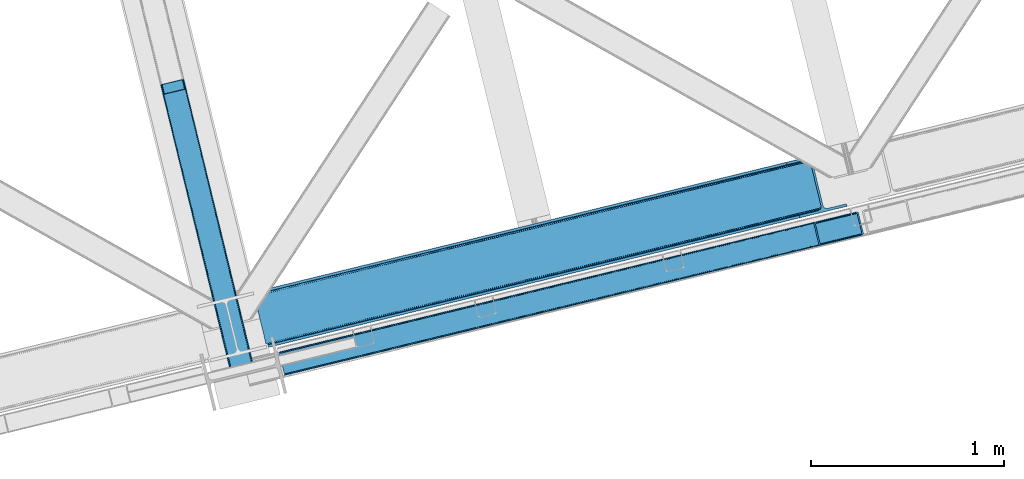
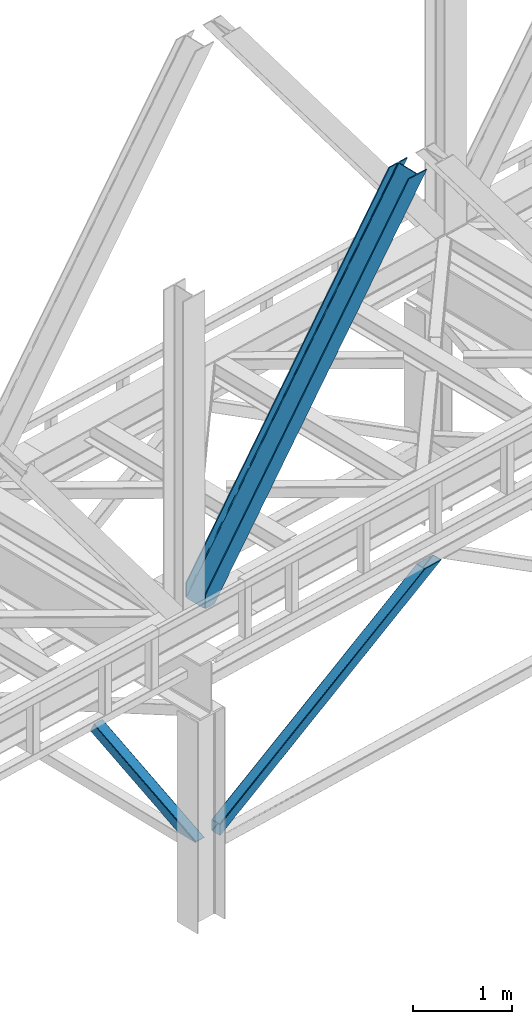
# One storey, part 43 of 92: 3 members.
"""IFC4 building model written with IfcOpenShell, lengths in millimetres."""

import ifcopenshell
import ifcopenshell.guid

model = None  # the IFC model being written
_history = None  # IfcOwnerHistory: only IFC2X3 demands one
_inside = {}  # id of a spatial element -> (the spatial element, [elements in it])
_under = {}  # id of a project, library or spatial element -> (it, [spatial elements below it])
_declared = {}  # id of a project -> (the project, [libraries it declares])
_typed = {}  # id of a type object -> (the type object, [elements of that type])
_made_of = {}  # id of a material, layer set ... -> (it, [elements and type objects made of it])


def new_model(schema):
    """Start an empty IFC model of exactly this schema.

    Asked for "IFC4X3", IfcOpenShell would pick the latest addendum, in which some entities
    have other attributes; the version numbers below select the first issue.
    IFC2X3 requires an IfcOwnerHistory on every rooted entity: one is made here for all.
    """
    global model, _history
    if schema == "IFC4X3":
        model = ifcopenshell.file(schema_version=(4, 3, 0, 0))
    else:
        model = ifcopenshell.file(schema=schema)
    _inside.clear()
    _under.clear()
    _declared.clear()
    _typed.clear()
    _made_of.clear()
    _history = None
    if model.schema == "IFC2X3":
        org = make("IfcOrganization", Name="unknown")
        user = make(
            "IfcPersonAndOrganization",
            ThePerson=make("IfcPerson", FamilyName="unknown"),
            TheOrganization=org,
        )
        app = make(
            "IfcApplication",
            ApplicationDeveloper=org,
            Version="unknown",
            ApplicationFullName="unknown",
            ApplicationIdentifier="unknown",
        )
        _history = make(
            "IfcOwnerHistory",
            OwningUser=user,
            OwningApplication=app,
            ChangeAction="ADDED",
            CreationDate=0,
        )
    return model


def make(cls, **values):
    """One entity of the class cls with the attributes given. An attribute that is None is left unset."""
    return model.create_entity(
        cls, **{name: value for name, value in values.items() if value is not None}
    )


def entity(cls, *values):
    """Any entity or typed value of the class cls, its attributes in the order of the schema. None: left unset."""
    e = model.create_entity(cls)
    for i, value in enumerate(values):
        if value is not None:
            e[i] = value
    return e


def rooted(cls, **values):
    """An entity with a GlobalId (a new one), such as an element, a storey or a relation."""
    return make(cls, GlobalId=ifcopenshell.guid.new(), OwnerHistory=_history, **values)


def si_unit(unit_type, name, prefix=None):
    """IfcSIUnit, for example si_unit("LENGTHUNIT", "METRE", prefix="MILLI")."""
    return make("IfcSIUnit", UnitType=unit_type, Prefix=prefix, Name=name)


def converted_unit(unit_type, name, factor, base, dimensions=None, offset=None):
    """IfcConversionBasedUnit, such as the inch: factor (a typed value) times the base unit."""
    return make(
        "IfcConversionBasedUnit"
        if offset is None
        else "IfcConversionBasedUnitWithOffset",
        ConversionOffset=offset,
        Dimensions=None
        if dimensions is None
        else entity("IfcDimensionalExponents", *dimensions),
        UnitType=unit_type,
        Name=name,
        ConversionFactor=make(
            "IfcMeasureWithUnit", ValueComponent=factor, UnitComponent=base
        ),
    )


def derived_unit(unit_type, elements):
    """IfcDerivedUnit: a product of units, each with its exponent."""
    return make(
        "IfcDerivedUnit",
        Elements=[
            make("IfcDerivedUnitElement", Unit=unit, Exponent=power)
            for unit, power in elements
        ],
        UnitType=unit_type,
    )


def assignment(units):
    """IfcUnitAssignment: the units of a project."""
    return None if units is None else make("IfcUnitAssignment", Units=units)


def point(xyz):
    """IfcCartesianPoint."""
    return None if xyz is None else make("IfcCartesianPoint", Coordinates=xyz)


def direction(xyz):
    """IfcDirection."""
    return None if xyz is None else make("IfcDirection", DirectionRatios=xyz)


def frame(location, z_axis=None, x_axis=None):
    """IfcAxis2Placement3D, a coordinate frame: its origin and axes. An axis left out is left unset."""
    return make(
        "IfcAxis2Placement3D",
        Location=point(location),
        Axis=direction(z_axis),
        RefDirection=direction(x_axis),
    )


def origin():
    """The frame at (0, 0, 0) with its axes left unset."""
    return frame((0.0, 0.0, 0.0))


def place(relative_to, where):
    """IfcLocalPlacement: puts the frame where relative to a parent placement (None: the world)."""
    return make(
        "IfcLocalPlacement", PlacementRelTo=relative_to, RelativePlacement=where
    )


def context(
    kind, dimensions, precision=None, world=None, true_north=None, identifier=None
):
    """IfcGeometricRepresentationContext, for example the 3D "Model" context."""
    return make(
        "IfcGeometricRepresentationContext",
        ContextIdentifier=identifier,
        ContextType=kind,
        CoordinateSpaceDimension=dimensions,
        Precision=precision,
        WorldCoordinateSystem=world,
        TrueNorth=true_north,
    )


def subcontext(parent, identifier, kind, view, scale=None):
    """IfcGeometricRepresentationSubContext, for example "Body" below "Model"."""
    return make(
        "IfcGeometricRepresentationSubContext",
        ContextIdentifier=identifier,
        ContextType=kind,
        ParentContext=parent,
        TargetScale=scale,
        TargetView=view,
    )


def project(units=None, contexts=None):
    """IfcProject with its units and contexts."""
    return rooted(
        "IfcProject",
        Name="project",
        RepresentationContexts=contexts,
        UnitsInContext=assignment(units),
    )


def spatial(cls, under=None, at=None, **own):
    """A site, building, storey or space (cls), placed at a placement, below another one or the project."""
    s = rooted(cls, ObjectPlacement=at, **own)
    if under is not None:
        _under.setdefault(under.id(), (under, []))[1].append(s)
    return s


def point_list(points):
    """IfcCartesianPointList2D or 3D."""
    cls = (
        "IfcCartesianPointList2D" if len(points[0]) == 2 else "IfcCartesianPointList3D"
    )
    return make(cls, CoordList=points)


def triangles(points, corners, closed=None, point_numbers=None):
    """IfcTriangulatedFaceSet: each triangle names its three corners, points numbered from 1."""
    return make(
        "IfcTriangulatedFaceSet",
        Coordinates=point_list(points),
        Closed=closed,
        CoordIndex=corners,
        PnIndex=point_numbers,
    )


def polygons(points, faces, closed=None, point_numbers=None):
    """IfcPolygonalFaceSet: a face is its outer loop, then its inner loops; points numbered from 1."""
    made = []
    for loops in faces:
        if len(loops) == 1:
            made.append(make("IfcIndexedPolygonalFace", CoordIndex=loops[0]))
        else:
            made.append(
                make(
                    "IfcIndexedPolygonalFaceWithVoids",
                    CoordIndex=loops[0],
                    InnerCoordIndices=loops[1:],
                )
            )
    return make(
        "IfcPolygonalFaceSet",
        Coordinates=point_list(points),
        Closed=closed,
        Faces=made,
        PnIndex=point_numbers,
    )


def shape(context_of_items, identifier, shape_type, items):
    """IfcShapeRepresentation: the items that make up one representation, for example the "Body"."""
    return make(
        "IfcShapeRepresentation",
        ContextOfItems=context_of_items,
        RepresentationIdentifier=identifier,
        RepresentationType=shape_type,
        Items=items,
    )


def made_of(thing, what):
    """Note that an element or type object is made of a material, layer set ...; save() writes the relation."""
    if what is not None:
        _made_of.setdefault(what.id(), (what, []))[1].append(thing)
    return thing


def type_object(cls, material=None, **own):
    """A type object (cls), such as IfcWallType, which elements share."""
    return made_of(rooted(cls, **own), material)


def element(
    cls,
    number,
    at=None,
    inside=None,
    cuts=None,
    type_object=None,
    material=None,
    context=None,
    identifier="Body",
    shape_type=None,
    held_by="IfcProductDefinitionShape",
    body=None,
    shapes=None,
    **own,
):
    """One element of the class cls, such as IfcWall. Its Tag is "e" and its number.

    at: its placement. inside: the storey or other place that contains it. cuts: it is an
    opening in that element (IfcRelVoidsElement). A single representation is given by context,
    identifier, shape_type and body (its items); several are given by shapes. held_by: the class
    of the entity that holds the representations. save() writes the other relations.
    """
    e = rooted(cls, Tag="e%d" % number, ObjectPlacement=at, **own)
    if body is not None:
        shapes = [shape(context, identifier, shape_type, body)]
    if shapes is not None:
        e.Representation = make(held_by, Representations=shapes)
    if inside is not None:
        _inside.setdefault(inside.id(), (inside, []))[1].append(e)
    if cuts is not None:
        rooted(
            "IfcRelVoidsElement", RelatingBuildingElement=cuts, RelatedOpeningElement=e
        )
    if type_object is not None:
        _typed.setdefault(type_object.id(), (type_object, []))[1].append(e)
    return made_of(e, material)


def aggregate(whole, parts):
    """IfcRelAggregates: a whole, such as a stair, and the parts it consists of."""
    return rooted("IfcRelAggregates", RelatingObject=whole, RelatedObjects=parts)


def save(model, path):
    """Write the relations noted so far, then the file.

    IfcRelAggregates (storeys below a building ...), IfcRelContainedInSpatialStructure (elements
    in a storey), IfcRelDefinesByType, IfcRelAssociatesMaterial and IfcRelDeclares: one each for
    every whole, place, type object, material and project.
    """
    for whole, parts in _under.values():
        aggregate(whole, parts)
    for where, things in _inside.values():
        rooted(
            "IfcRelContainedInSpatialStructure",
            RelatedElements=things,
            RelatingStructure=where,
        )
    for kind, things in _typed.values():
        rooted("IfcRelDefinesByType", RelatedObjects=things, RelatingType=kind)
    for what, things in _made_of.values():
        rooted("IfcRelAssociatesMaterial", RelatedObjects=things, RelatingMaterial=what)
    for by, libraries in _declared.values():
        rooted("IfcRelDeclares", RelatingContext=by, RelatedDefinitions=libraries)
    model.write(path)


model = new_model("IFC4")

# Units and contexts
model_context = context("Model", 3, precision=0.01, world=origin(), true_north=direction((6.12303176911189e-17, 1.0)))
plan_context = context("Plan", 3, precision=0.01, world=origin(), true_north=direction((6.12303176911189e-17, 1.0)))
body_context = subcontext(model_context, "Body", "Model", "MODEL_VIEW")
ifc_project = project(units=[si_unit("LENGTHUNIT", "METRE", prefix="MILLI"), si_unit("AREAUNIT", "SQUARE_METRE"), si_unit("VOLUMEUNIT", "CUBIC_METRE"), converted_unit("PLANEANGLEUNIT", "DEGREE", entity("IfcRatioMeasure", 0.0174532925199433), si_unit("PLANEANGLEUNIT", "RADIAN"), dimensions=[0, 0, 0, 0, 0, 0, 0]), si_unit("MASSUNIT", "GRAM", prefix="KILO"), derived_unit("MASSDENSITYUNIT", [(si_unit("MASSUNIT", "GRAM", prefix="KILO"), 1), (si_unit("LENGTHUNIT", "METRE"), -3)]), derived_unit("MOMENTOFINERTIAUNIT", [(si_unit("LENGTHUNIT", "METRE"), 4)]), si_unit("TIMEUNIT", "SECOND"), si_unit("FREQUENCYUNIT", "HERTZ"), si_unit("THERMODYNAMICTEMPERATUREUNIT", "DEGREE_CELSIUS"), derived_unit("THERMALTRANSMITTANCEUNIT", [(si_unit("MASSUNIT", "GRAM", prefix="KILO"), 1), (si_unit("THERMODYNAMICTEMPERATUREUNIT", "KELVIN"), -1), (si_unit("TIMEUNIT", "SECOND"), -3)]), derived_unit("VOLUMETRICFLOWRATEUNIT", [(si_unit("LENGTHUNIT", "METRE"), 3), (si_unit("TIMEUNIT", "SECOND"), -1)]), derived_unit("MASSFLOWRATEUNIT", [(si_unit("MASSUNIT", "GRAM", prefix="KILO"), 1), (si_unit("TIMEUNIT", "SECOND"), -1)]), derived_unit("ROTATIONALFREQUENCYUNIT", [(si_unit("TIMEUNIT", "SECOND"), -1)]), si_unit("ELECTRICCURRENTUNIT", "AMPERE"), si_unit("ELECTRICVOLTAGEUNIT", "VOLT"), si_unit("POWERUNIT", "WATT"), si_unit("FORCEUNIT", "NEWTON", prefix="KILO"), si_unit("ILLUMINANCEUNIT", "LUX"), si_unit("LUMINOUSFLUXUNIT", "LUMEN"), si_unit("LUMINOUSINTENSITYUNIT", "CANDELA"), derived_unit("USERDEFINED", [(si_unit("MASSUNIT", "GRAM", prefix="KILO"), -1), (si_unit("LENGTHUNIT", "METRE"), -2), (si_unit("TIMEUNIT", "SECOND"), 3), (si_unit("LUMINOUSFLUXUNIT", "LUMEN"), 1)]), derived_unit("LINEARVELOCITYUNIT", [(si_unit("LENGTHUNIT", "METRE"), 1), (si_unit("TIMEUNIT", "SECOND"), -1)]), si_unit("PRESSUREUNIT", "PASCAL"), derived_unit("USERDEFINED", [(si_unit("LENGTHUNIT", "METRE"), -2), (si_unit("MASSUNIT", "GRAM", prefix="KILO"), 1), (si_unit("TIMEUNIT", "SECOND"), -2)]), derived_unit("LINEARFORCEUNIT", [(si_unit("MASSUNIT", "GRAM", prefix="KILO"), 1), (si_unit("LENGTHUNIT", "METRE"), 1), (si_unit("TIMEUNIT", "SECOND"), -2), (si_unit("LENGTHUNIT", "METRE"), -1)]), derived_unit("PLANARFORCEUNIT", [(si_unit("MASSUNIT", "GRAM", prefix="KILO"), 1), (si_unit("LENGTHUNIT", "METRE"), 1), (si_unit("TIMEUNIT", "SECOND"), -2), (si_unit("LENGTHUNIT", "METRE"), -2)])], contexts=[model_context, plan_context])

# Site, building, storey
site_placement = place(None, origin())
site = spatial("IfcSite", under=ifc_project, at=site_placement, CompositionType="ELEMENT")
building_placement = place(site_placement, origin())
building = spatial("IfcBuilding", under=site, at=building_placement, CompositionType="ELEMENT")
storey_placement = place(building_placement, frame((0.0, 0.0, 15900.0)))
storey = spatial("IfcBuildingStorey", under=building, at=storey_placement, Name="05", CompositionType="ELEMENT", Elevation=15900.0)

# Members
member_type_1 = type_object("IfcMemberType", PredefinedType="BRACE")
member_1_placement = place(storey_placement, frame((-41961.07, 7062.35, 965.74)))
element("IfcMember", 1, at=member_1_placement, inside=storey, type_object=member_type_1, ObjectType="Steel Vertical Brace", PredefinedType="BRACE", context=body_context, shape_type="Tessellation", body=[
    triangles([(2998.54487915039, 840.490557861329, 1902.27225952148), (3024.23633422852, 734.561558532715, 1902.27225952148), (42.5415893554673, 11.3696548461912, 4.45903015136719), (16.6222412109346, 117.244006347656, 4.31717834472511), (0.176733398438955, 120.724607849122, 0.782510375975107), (0.0, 121.44375, 4.34159545898365), (2981.88078002929, 844.680418395997, 1902.27225952148), (2987.68042602539, 845.46060333252, 1902.27225952148), (2992.88243408203, 844.93796081543, 1902.27225952148), (7.26932373047021, 120.796115112305, 1.96615905761428), (2996.69848022461, 843.192718505859, 1902.27225952148), (13.8131103515625, 119.713041687012, 3.70442504882521), (0.213940429683134, 120.566477966308, 0.0), (3016.85538940429, 725.165620422364, 1902.27225952148), (29.4307617187515, 0.712165832519531, 0.868551635740005), (35.8768798828096, 3.93231811523492, 2.12312622070021), (29.3935546875, 0.86041259765625, 0.127899169921875), (3011.34642333984, 723.202949523926, 1902.27225952148), (29.6028442382813, 0.0, 4.43112487792678), (3021.24349365234, 728.014283752442, 1902.27225952148), (3023.83403320312, 731.313500976563, 1902.27225952148), (41.1835327148438, 7.89079742431659, 3.85441589355469), (0.0, 121.44375, 132.509353637695), (2780.51400146484, 795.840376281739, 1902.27225952148), (0.27440185546584, 120.305447387695, 135.835894775388), (2775.00270996094, 793.876542663575, 1902.27225952148), (0.55345458984084, 119.167726135254, 139.162435913084), (2770.61693115234, 791.02846069336, 1902.27225952148), (1.22318115234521, 116.419638061524, 140.541421508788), (2768.02639160156, 787.729243469239, 1902.27225952148), (1.89290771484229, 113.671549987793, 141.921569824219), (2767.62176513672, 784.481185913086, 1902.27225952148), (2793.31322021484, 678.552767944337, 1902.27225952148), (27.709936523439, 7.77220001220758, 141.999472045896), (28.379663085936, 5.02411193847638, 140.622811889647), (2795.15961914062, 675.850025939942, 1902.27225952148), (29.0493896484331, 2.27660522460974, 139.247314453125), (2798.97333984375, 674.104783630371, 1902.27225952148), (29.3237915039063, 1.13830261230487, 135.92309875488), (2804.17767333984, 673.582722473145, 1902.27225952148), (29.6028442382813, 0.0, 132.597720336911), (2809.97731933594, 674.362326049805, 1902.27225952148), (3.90208740234084, 110.042120361329, 0.32207336425563), (27.914575195311, 11.9382247924805, 0.453460693359375), (27.3053100585894, 9.42209930419904, 0.118597412107192), (2.32078857421584, 111.926307678223, 0.00930175781104481), (3015.90428466797, 736.656198120118, 1902.27225952148), (2992.09876098633, 834.810671997071, 1902.27225952148), (1.62315673827834, 114.773808288574, 3.08236999511428), (2986.43864135742, 839.258656311035, 1902.27225952148), (2981.23430786133, 839.780717468262, 1902.27225952148), (2.17196044921729, 112.539060974122, 0.67088928222438), (2990.25236206054, 837.513414001465, 1902.27225952148), (1.09295654296875, 116.966116333008, 5.44850463866896), (2975.43466186523, 839.001113891602, 1902.27225952148), (0.94877929687209, 117.557940673828, 9.04828491210719), (28.379663085936, 5.02411193847638, 5.80429687499782), (28.6540649414019, 3.88580932617242, 9.13083801269386), (3003.01204833984, 725.297589111328, 1902.27225952148), (28.100610351561, 6.16241455078125, 2.47775573730178), (3008.5256652832, 727.261422729493, 1902.27225952148), (27.4680908203081, 8.76167449951208, 0.596475219725107), (3012.90911865234, 730.108923339844, 1902.27225952148), (3015.50198364258, 733.408721923828, 1902.27225952148), (0.94877929687209, 117.557940673828, 127.808477783201), (2788.84837646484, 793.745155334473, 1902.27225952148), (2.17196044921729, 112.533247375489, 135.841708374021), (2776.35611572266, 785.634603881836, 1902.27225952148), (2775.95148925781, 782.385964965821, 1902.27225952148), (1.50223388672021, 115.281335449219, 134.461560058593), (2778.95130615234, 788.933821105958, 1902.27225952148), (1.22318115234521, 116.419638061524, 131.135018920897), (2783.33708496093, 791.781903076172, 1902.27225952148), (2.84168701171438, 109.785159301758, 137.220693969724), (2805.42410888672, 679.784669494629, 1902.27225952148), (2801.60573730469, 681.529911804199, 1902.27225952148), (2816.4234375, 680.041630554199, 1902.27225952148), (2810.62844238281, 679.26202697754, 1902.27225952148), (2799.75933837891, 684.231491088867, 1902.27225952148), (28.379663085936, 5.02411193847638, 131.216409301756), (28.100610351561, 6.16241455078125, 134.541787719725), (27.430883789064, 8.91050262451154, 135.917285156247), (26.7611572265596, 11.6585906982427, 137.292782592773), (28.6540649414019, 3.88580932617242, 127.891030883788)], [[1, 2, 3], [3, 4, 1], [5, 6, 7], [8, 9, 10], [10, 5, 8], [11, 1, 4], [4, 12, 11], [9, 11, 12], [12, 10, 9], [10, 13, 5], [7, 8, 5], [14, 15, 16], [15, 17, 16], [15, 14, 18], [18, 19, 15], [16, 20, 14], [21, 20, 22], [16, 22, 20], [2, 21, 3], [22, 3, 21], [6, 23, 24], [24, 7, 6], [23, 25, 26], [25, 27, 28], [27, 29, 30], [29, 31, 32], [32, 30, 29], [30, 28, 27], [28, 26, 25], [26, 24, 23], [33, 32, 34], [31, 34, 32], [35, 36, 33], [37, 38, 36], [39, 40, 38], [41, 42, 40], [40, 39, 41], [38, 37, 39], [36, 35, 37], [33, 34, 35], [41, 19, 42], [18, 42, 19], [43, 10, 12], [44, 3, 22], [44, 22, 16], [3, 44, 4], [12, 4, 43], [43, 4, 44], [16, 45, 44], [16, 17, 45], [10, 46, 13], [46, 10, 43], [47, 48, 44], [43, 44, 48], [49, 50, 51], [52, 53, 50], [53, 46, 43], [53, 52, 46], [43, 48, 53], [50, 49, 52], [51, 54, 49], [51, 55, 54], [56, 54, 55], [57, 58, 59], [60, 57, 61], [62, 60, 63], [64, 47, 44], [44, 45, 64], [45, 62, 64], [63, 64, 62], [61, 63, 60], [59, 61, 57], [65, 56, 66], [55, 66, 56], [67, 68, 69], [70, 71, 68], [72, 73, 71], [65, 66, 73], [73, 72, 65], [71, 70, 72], [68, 67, 70], [69, 74, 67], [53, 9, 8], [48, 2, 1], [11, 53, 1], [53, 11, 9], [53, 48, 1], [50, 53, 8], [55, 7, 24], [7, 50, 8], [51, 7, 55], [51, 50, 7], [20, 64, 14], [47, 2, 48], [2, 64, 21], [64, 2, 47], [20, 21, 64], [18, 59, 42], [14, 64, 63], [63, 61, 18], [61, 59, 18], [18, 14, 63], [71, 26, 68], [24, 66, 55], [24, 73, 66], [71, 24, 26], [71, 73, 24], [69, 32, 33], [68, 26, 28], [30, 68, 28], [68, 30, 32], [69, 68, 32], [40, 75, 76], [42, 59, 77], [77, 78, 42], [78, 75, 42], [40, 42, 75], [38, 40, 76], [33, 79, 69], [76, 33, 36], [33, 76, 79], [36, 38, 76], [41, 39, 80], [81, 35, 82], [37, 81, 39], [81, 37, 35], [80, 39, 81], [83, 31, 74], [82, 35, 34], [34, 83, 82], [34, 31, 83], [80, 84, 41], [19, 60, 17], [19, 41, 84], [84, 58, 19], [19, 58, 57], [60, 19, 57], [60, 62, 17], [23, 65, 72], [70, 25, 72], [31, 29, 67], [31, 67, 74], [67, 29, 70], [25, 23, 72], [70, 29, 27], [70, 27, 25], [23, 56, 65], [49, 13, 46], [49, 54, 5], [5, 13, 49], [54, 56, 6], [23, 6, 56], [54, 6, 5], [69, 79, 83], [83, 74, 69], [84, 80, 78], [80, 81, 75], [81, 82, 76], [82, 83, 79], [79, 76, 82], [76, 75, 81], [75, 78, 80], [78, 77, 84], [58, 84, 77], [77, 59, 58]]),
])
member_type_2 = type_object("IfcMemberType", PredefinedType="BRACE")
member_2_placement = place(storey_placement, frame((-42089.44, 7208.3, 3695.0)))
element("IfcMember", 2, at=member_2_placement, inside=storey, type_object=member_type_2, ObjectType="Steel Vertical Brace", PredefinedType="BRACE", context=body_context, shape_type="Tessellation", body=[
    triangles([(58.5266601562471, 27.8796936035151, 0.0), (60.4474731445298, 20.0011047363278, 0.0), (59.0940673828154, 20.928955078125, 0.827856445310317), (58.9684936523408, 19.7534454345705, 1.13248901367115), (72.2095458984404, 11.6585906982418, 0.0), (71.3956420898467, 13.9003143310547, 30.563250732419), (70.2236206054658, 15.4356857299799, 25.1542785644524), (72.2095458984404, 11.6585906982418, 171.175598144531), (71.9258422851563, 12.6195785522459, 42.2602111816377), (71.9258422851563, 12.6195785522459, 171.115136718749), (70.3910522460938, 15.5600967407227, 0.0), (68.8144042968779, 17.2873168945307, 18.6337463378877), (67.2145019531235, 18.4651519775389, 14.6921264648408), (63.168237304686, 19.929597473144, 7.29955444335792), (63.168237304686, 19.929597473144, 0.0), (67.2145019531235, 18.4651519775389, 0.0), (2821.27895507812, 682.803089904785, 3911.00081176758), (2916.00805664063, 705.89354095459, 3911.00081176758), (2933.63488769531, 721.627464294434, 3911.00081176758), (2930.26300048828, 714.795323181153, 3911.00081176758), (2933.67209472656, 728.727030944824, 3911.00081176758), (2924.07268066406, 709.270079040527, 3911.00081176758), (2824.35783691406, 670.173046875, 3911.00081176758), (75.0512329101548, 0.0, 171.175598144531), (75.0512329101548, 0.0, 0.0), (192.881249999999, 28.7220840454102, 0.0), (3068.02668457032, 729.569421386719, 3911.00081176758), (3064.94780273437, 742.199464416504, 3911.00081176758), (189.802368164063, 41.3521270751953, 0.0), (2970.22335205078, 719.109594726562, 3911.00081176758), (95.0779174804702, 18.2622573852541, 0.0), (2961.50295410156, 718.394522094726, 3911.00081176758), (86.3575195312515, 17.5477661132809, 0.0), (2953.46623535156, 720.451373291015, 3911.00081176758), (78.32080078125, 19.6040359497065, 0.0), (2947.32707519531, 724.966213989258, 3911.00081176758), (72.181640625, 24.118876647949, 0.0), (2944.02960205078, 731.251295471191, 3911.00081176758), (68.8841674804717, 30.403958129883, 0.0), (2888.84692382813, 957.622943115234, 3911.00081176758), (13.7014892578154, 256.775605773926, 0.0), (2888.88413085938, 964.722509765625, 3911.00081176758), (13.7386962890596, 263.875172424317, 0.0), (2892.25601806641, 971.554650878907, 3911.00081176758), (17.1105834960908, 270.707313537598, 0.0), (2898.44633789062, 977.079895019531, 3911.00081176758), (23.3009033203125, 276.232557678222, 0.0), (2906.51561279297, 980.457014465332, 3911.00081176758), (31.3701782226563, 279.609677124024, 0.0), (3001.24006347657, 1003.54746551514, 3911.00081176758), (126.094628906249, 302.700128173828, 0.0), (2998.16118164062, 1016.17750854492, 3911.00081176758), (123.015747070313, 315.330171203614, 0.0), (2878.48941650391, 955.098678588867, 3911.00081176758), (3.34398193359084, 254.251341247558, 0.0), (2869.05278320312, 965.898600769043, 3911.00081176758), (2861.01606445313, 967.955451965332, 3911.00081176758), (2754.49233398437, 956.78055267334, 3911.00081176758), (2852.30031738281, 967.241542053222, 3911.00081176758), (2757.57121582031, 944.150509643555, 3911.00081176758), (2875.19194335937, 961.383760070801, 3911.00081176758), (5.18572998046875, 286.608087158203, 171.175598144531), (5.18572998046875, 286.608087158203, 0.0), (8.02741699219041, 274.949496459961, 171.175598144531), (8.22275390625146, 273.966998291015, 171.115136718749), (8.22275390625146, 273.966998291015, 42.2602111816377), (8.02741699219041, 274.949496459961, 0.0), (3.80906982421584, 263.445547485351, 0.0), (6.72517089844041, 266.608145141601, 0.0), (8.20880126953125, 270.64917755127, 0.0), (1.42316894531541, 262.130511474609, 0.0), (3.80906982421584, 263.445547485351, 7.29955444335792), (8.33902587890771, 272.585105895996, 30.563250732419), (8.20880126953125, 270.64917755127, 24.1799194335908), (7.30653076172166, 268.181886291504, 18.3872497558586), (6.72517089844041, 266.608145141601, 14.6921264648408), (0.0, 261.670074462891, 1.13248901367115), (0.651123046875, 260.685250854493, 0.827856445310317)], [[1, 2, 3], [4, 3, 2], [5, 6, 7], [5, 8, 9], [10, 9, 8], [9, 6, 5], [11, 12, 13], [11, 7, 12], [14, 4, 2], [2, 15, 14], [16, 13, 14], [14, 15, 16], [13, 16, 11], [7, 11, 5], [17, 18, 10], [9, 10, 18], [19, 3, 14], [14, 20, 19], [14, 13, 20], [13, 12, 20], [3, 4, 14], [19, 21, 1], [1, 3, 19], [6, 20, 7], [6, 22, 20], [12, 7, 20], [18, 22, 9], [6, 9, 22], [8, 17, 10], [23, 8, 24], [8, 23, 17], [25, 24, 5], [8, 5, 24], [23, 26, 27], [26, 23, 24], [25, 26, 24], [28, 27, 26], [26, 29, 28], [30, 28, 29], [29, 31, 30], [32, 30, 31], [31, 33, 32], [34, 32, 33], [33, 35, 34], [36, 34, 35], [35, 37, 36], [38, 36, 37], [37, 39, 38], [40, 38, 39], [39, 41, 40], [42, 40, 43], [41, 43, 40], [44, 42, 45], [43, 45, 42], [46, 44, 47], [45, 47, 44], [48, 46, 49], [47, 49, 46], [50, 48, 51], [49, 51, 48], [52, 50, 51], [51, 53, 52], [21, 54, 55], [55, 1, 21], [54, 21, 40], [20, 22, 32], [18, 23, 27], [17, 23, 18], [22, 18, 30], [21, 19, 36], [19, 20, 34], [56, 46, 57], [58, 59, 52], [59, 57, 48], [58, 60, 59], [56, 61, 44], [61, 54, 42], [40, 21, 38], [30, 32, 22], [36, 19, 34], [32, 34, 20], [36, 38, 21], [27, 30, 18], [27, 28, 30], [48, 57, 46], [44, 61, 42], [40, 42, 54], [44, 46, 56], [48, 52, 59], [52, 48, 50], [58, 53, 62], [58, 52, 53], [53, 63, 62], [64, 58, 62], [60, 64, 65], [64, 60, 58], [59, 60, 65], [65, 66, 59], [67, 64, 62], [62, 63, 67], [11, 35, 5], [68, 41, 55], [69, 70, 43], [69, 43, 68], [55, 71, 68], [67, 63, 47], [67, 45, 70], [55, 39, 1], [37, 16, 15], [2, 1, 15], [15, 1, 39], [11, 16, 37], [25, 5, 33], [39, 55, 41], [49, 47, 63], [43, 70, 45], [47, 45, 67], [43, 41, 68], [53, 49, 63], [53, 51, 49], [31, 25, 33], [35, 11, 37], [39, 37, 15], [35, 33, 5], [31, 26, 25], [26, 31, 29], [72, 68, 71], [67, 73, 66], [67, 70, 74], [74, 73, 67], [64, 67, 66], [66, 65, 64], [75, 70, 76], [75, 74, 70], [69, 76, 70], [76, 69, 72], [68, 72, 69], [71, 77, 72], [78, 61, 72], [61, 56, 75], [75, 76, 61], [76, 72, 61], [56, 57, 73], [73, 74, 56], [57, 59, 66], [66, 73, 57], [74, 75, 56], [72, 77, 78], [54, 61, 55], [78, 55, 61], [71, 55, 78], [78, 77, 71]]),
])
member_type_3 = type_object("IfcMemberType", PredefinedType="BRACE")
member_3_placement = place(storey_placement, frame((-42573.75, 7071.33, 970.5)))
element("IfcMember", 3, at=member_3_placement, inside=storey, type_object=member_type_3, ObjectType="Steel Vertical Brace", PredefinedType="BRACE", context=body_context, shape_type="Tessellation", body=[
    polygons([(310.156875969811, 236.659699185643, 1.04388391264365e-09), (309.042346364983, 243.80328395698, 1.04171817838505e-09), (4.57230123623604, 1492.85694714149, 603.530503671959), (4.28876445601391, 1491.44877039324, 606.301796687595), (309.280773738958, 250.147759710236, 1.04604964690225e-09), (5.99595206163992, 1494.33917875157, 601.181114896126), (310.835859685345, 254.727237524783, 1.04604964690225e-09), (8.34297899944397, 1495.6698088973, 599.611303503947), (313.470856465746, 256.844533416439, 1.04604964690225e-09), (11.2560684742403, 1496.64626120118, 599.060059049498), (366.444630080972, 5.7456024138507, 1.00706643024751e-09), (14.4533090982387, 1449.74988433501, 697.72873436856), (411.597614338037, 280.763968808463, 1.04171817838505e-09), (109.38282634654, 1520.56569659321, 599.060059049498), (425.485457020332, 274.46076918091, 1.03522097560926e-09), (485.172065028787, 29.6032616237778, 9.24768528420827e-10), (481.0136271769, 28.5895984014798, 9.24768528420827e-10), (480.116220883526, 33.45425529372, 9.72414682109957e-10), (423.828466772364, 264.368352065512, 1.03305524135067e-09), (421.530657217859, 271.22349983026, 1.03522097560926e-09), (418.399388388624, 276.746576483304, 1.04171817838505e-09), (414.911367578928, 280.096743671035, 1.04171817838505e-09), (367.886495613074, 1.01366322182258, 9.29099996938021e-10), (363.72805776111, 1.08286712929839e-12, 5.76085312786745e-10), (304.041449752647, 244.857507557118, 1.03522097560926e-09), (302.926920147819, 252.001092328464, 1.03738670986786e-09), (303.165347521759, 258.345568081721, 1.03738670986786e-09), (304.720433468172, 262.925045896267, 1.04604964690225e-09), (307.355430248582, 265.042341787917, 1.04388391264365e-09), (413.254604585996, 290.856385923864, 1.04604964690225e-09), (416.568357826887, 290.18916078644, 1.05038111541944e-09), (420.056378636591, 286.838993598712, 1.04171817838505e-09), (423.18764746581, 281.315916945664, 1.04171817838505e-09), (112.418486893019, 1521.03931504355, 599.611303503942), (115.114566711323, 1520.93799552464, 601.181114896124), (117.060612089113, 1520.27716301478, 603.530503671959), (117.960355258576, 1519.15742327311, 606.301796687595), (128.124899900792, 1477.45853721488, 697.72873436856), (127.84136312057, 1476.05036046663, 700.500027384193), (126.417712295192, 1474.56812885655, 702.849416160034), (124.07068535738, 1473.23749871082, 704.419227552215), (121.157595882575, 1472.26104640693, 704.970472006657), (23.0308380102839, 1448.34161101491, 704.970472006657), (19.9951774637964, 1447.86799256457, 704.419227552218), (17.2990976454918, 1447.96931208348, 702.849416160031), (15.3530522677024, 1448.63014459335, 700.500027384193), (112.866478355649, 1523.16444199718, 595.439190230451), (6.9673040182264, 1497.35039786123, 595.439190230451), (4.05421454341274, 1496.37394555734, 595.990434684895), (1.70718760560003, 1495.04331541162, 597.560246077074), (0.28353678022213, 1493.56108380154, 599.909634852911), (0.0, 1492.15290705329, 602.680927868548), (10.9696570891299, 1447.15113893104, 701.349603187608), (11.8694002586022, 1446.03139918938, 704.120896203244), (13.8154456363916, 1445.37056667951, 706.470284979081), (16.5115254546789, 1445.2692471606, 708.040096371263), (19.5471860011663, 1445.74286561094, 708.591340825705), (125.446360338597, 1471.55690974689, 708.591340825705), (128.359449813402, 1472.53336205077, 708.040096371265), (130.706476751215, 1473.8639921965, 706.470284979079), (132.130127576593, 1475.34622380658, 704.120896203244), (132.413664356815, 1476.75440055483, 701.349603187608), (121.444007267685, 1521.75616867708, 602.680927868548), (120.544264098221, 1522.87590841874, 599.909634852913), (118.598218720423, 1523.53674092861, 597.560246077077), (115.902138902136, 1523.63806044752, 595.990434684897), (375.386682458807, 2.84191311588595, 6.51916727653314), (372.638718264444, 2.17206777061952, 5.2249222388966), (369.890754070107, 1.50222242536609, 3.93067720124058), (368.373326648033, 1.13233343716275, 0.954754934343811), (480.407239662007, 28.4417850297799, 0.783330976602792), (478.425418155212, 27.9586950702373, 3.34344663920135), (476.487815341744, 27.4863838850221, 5.84644062407408), (473.513440331098, 26.7613485079091, 6.51916727653314), (485.172065028795, 29.6032616237615, 2.10033831597304), (484.033820990575, 29.325802597071, 5.22492223888794), (482.895576952364, 29.0483435703729, 8.34950616180717), (480.147612758018, 28.3784982251108, 9.64375119945237), (477.399648563664, 27.7086528798498, 10.9379962370932), (371.500474226233, 1.8946087439236, 10.9379962370954), (368.752510031887, 1.22476339866151, 9.6437511994502), (366.004545837558, 0.55491805340375, 8.34950616180934), (364.866301799321, 0.277459026701334, 5.2249222388901), (363.72805776111, 2.16573425859679e-12, 2.10033831597304)], [[[1, 2, 3, 4]], [[2, 5, 6, 3]], [[5, 7, 8, 6]], [[7, 9, 10, 8]], [[11, 1, 4, 12]], [[9, 13, 14, 10]], [[15, 16, 17, 18, 19, 20, 21, 22, 13, 9, 7, 5, 2, 1, 11, 23, 24, 25, 26, 27, 28, 29, 30, 31, 32, 33]], [[47, 48, 49, 50, 51, 52, 53, 54, 55, 56, 57, 58, 59, 60, 61, 62, 63, 64, 65, 66], [10, 14, 34, 35, 36, 37, 38, 39, 40, 41, 42, 43, 44, 45, 46, 12, 4, 3, 6, 8]], [[13, 22, 34, 14]], [[22, 21, 35, 34]], [[21, 20, 36, 35]], [[20, 19, 37, 36]], [[19, 18, 38, 37]], [[44, 67, 68]], [[45, 68, 69]], [[46, 69, 70]], [[46, 11, 12]], [[11, 70, 23]], [[11, 46, 70]], [[69, 46, 45]], [[68, 45, 44]], [[67, 44, 43]], [[71, 18, 17]], [[39, 72, 40]], [[40, 73, 41]], [[73, 74, 42, 41]], [[73, 40, 72]], [[72, 39, 71]], [[39, 18, 71]], [[18, 39, 38]], [[42, 74, 67, 43]], [[16, 75, 76, 77, 78, 79, 80, 81, 82, 83, 84, 24, 23, 70, 69, 68, 67, 74, 73, 72, 71, 17]], [[29, 28, 49, 48]], [[28, 27, 50, 49]], [[27, 26, 51, 50]], [[26, 25, 52, 51]], [[47, 30, 29, 48]], [[15, 33, 64, 63]], [[33, 32, 65, 64]], [[32, 31, 66, 65]], [[31, 30, 47, 66]], [[24, 84, 53, 52, 25]], [[75, 16, 15, 63, 62]], [[53, 83, 54]], [[54, 82, 55]], [[55, 81, 56]], [[56, 80, 57]], [[80, 56, 81]], [[81, 55, 82]], [[82, 54, 83]], [[83, 53, 84]], [[80, 79, 58, 57]], [[59, 79, 78]], [[60, 78, 77]], [[61, 77, 76]], [[62, 76, 75]], [[76, 62, 61]], [[77, 61, 60]], [[78, 60, 59]], [[79, 59, 58]]], closed=True),
])

save(model, "model.ifc")
